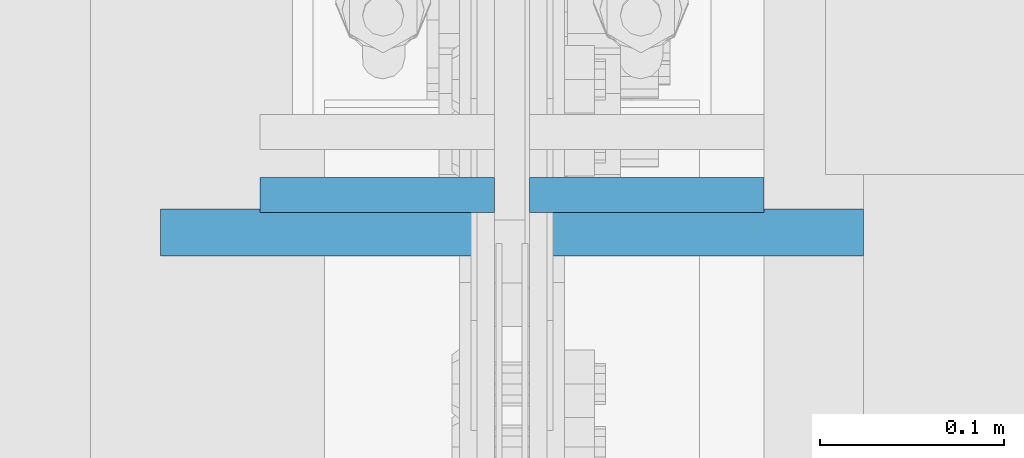
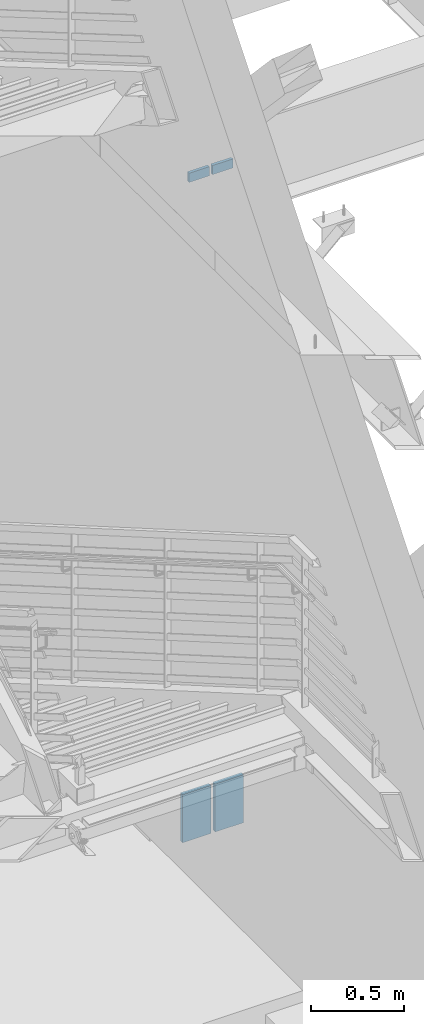
# One storey, part 490 of 1179: 4 columns, 4 elements without a shape of their own.
"""IFC2X3 building model written with IfcOpenShell, lengths in millimetres."""

from ifc_helpers import new_model, si_unit, frame, origin_with_axes, place, context, subcontext, project, spatial, faceted_brep, material, type_object, element, aggregate, save


model = new_model("IFC2X3")

# Units and contexts
model_context = context("Model", 3, precision=1e-05, world=origin_with_axes())
body_context = subcontext(model_context, "Body", "Model", "MODEL_VIEW")
ifc_project = project(units=[si_unit("LENGTHUNIT", "METRE", prefix="MILLI"), si_unit("AREAUNIT", "SQUARE_METRE"), si_unit("VOLUMEUNIT", "CUBIC_METRE"), si_unit("MASSUNIT", "GRAM", prefix="KILO"), si_unit("TIMEUNIT", "SECOND"), si_unit("PLANEANGLEUNIT", "RADIAN"), si_unit("SOLIDANGLEUNIT", "STERADIAN"), si_unit("THERMODYNAMICTEMPERATUREUNIT", "DEGREE_CELSIUS"), si_unit("LUMINOUSINTENSITYUNIT", "LUMEN")], contexts=[model_context])

# Site, building, storey
site_placement = place(None, origin_with_axes())
site = spatial("IfcSite", under=ifc_project, at=site_placement, CompositionType="ELEMENT")
building_placement = place(site_placement, origin_with_axes())
building = spatial("IfcBuilding", under=site, at=building_placement, Name="Undefined", CompositionType="ELEMENT")
storey_placement = place(building_placement, origin_with_axes())
storey = spatial("IfcBuildingStorey", under=building, at=storey_placement, Name="Undefined", CompositionType="ELEMENT", Elevation=0.0)

# Assembly, column
assembly_1_placement = place(storey_placement, origin_with_axes())
assembly_1 = element("IfcElementAssembly", 1, at=assembly_1_placement, inside=storey, Name="PLATE", AssemblyPlace="NOTDEFINED", PredefinedType="RIGID_FRAME")
ifc_material = material(Name="STEEL/A572-GR.50")
column_type_1 = type_object("IfcColumnType", PredefinedType="NOTDEFINED")
column_1_placement = place(assembly_1_placement, frame((330.2, 33931.2801619231, -215.9), z_axis=(1.0, 0.0, 0.0), x_axis=(0.0, 0.0, 1.0)))
column_1 = element("IfcColumn", 2, at=column_1_placement, type_object=column_type_1, material=ifc_material, Name="PLATE", context=body_context, shape_type="Brep", body=[
    faceted_brep([(0.0, 12.6999999999998, -88.9000000000015), (0.0, 12.6999999999998, 88.9000000000015), (314.840055491836, 12.7000000000007, 88.9000000000015), (314.840055491836, 12.7000000000007, -88.9000000000015), (0.0, -12.6999999999998, 88.9000000000015), (314.840055491836, -12.7000000000007, 88.9000000000015), (0.0, -12.6999999999998, -88.9000000000015), (314.840055491836, -12.7000000000007, -88.9000000000015)], [[[0, 1, 2, 3]], [[1, 4, 5, 2]], [[4, 6, 7, 5]], [[6, 0, 3, 7]], [[5, 7, 3, 2]], [[6, 4, 1, 0]]]),
])
aggregate(assembly_1, [column_1])

assembly_2_placement = place(storey_placement, origin_with_axes())
assembly_2 = element("IfcElementAssembly", 3, at=assembly_2_placement, inside=storey, Name="PLATE", AssemblyPlace="NOTDEFINED", PredefinedType="RIGID_FRAME")
column_2_placement = place(assembly_2_placement, frame((533.4, 33931.2801619231, -215.9), z_axis=(-1.0, 0.0, 0.0), x_axis=(0.0, 0.0, 1.0)))
column_2 = element("IfcColumn", 4, at=column_2_placement, type_object=column_type_1, material=ifc_material, Name="PLATE", context=body_context, shape_type="Brep", body=[
    faceted_brep([(0.0, 12.6999999999998, -88.9000000000015), (0.0, 12.6999999999998, 88.9000000000015), (314.840055491836, 12.7000000000007, 88.9000000000015), (314.840055491836, 12.7000000000007, -88.9000000000015), (0.0, -12.6999999999998, 88.9000000000015), (314.840055491836, -12.7000000000007, 88.9000000000015), (0.0, -12.6999999999998, -88.9000000000015), (314.840055491836, -12.7000000000007, -88.9000000000015)], [[[0, 1, 2, 3]], [[1, 4, 5, 2]], [[4, 6, 7, 5]], [[6, 0, 3, 7]], [[5, 7, 3, 2]], [[6, 4, 1, 0]]]),
])
aggregate(assembly_2, [column_2])

assembly_3_placement = place(storey_placement, origin_with_axes())
assembly_3 = element("IfcElementAssembly", 5, at=assembly_3_placement, inside=storey, Name="PLATE", AssemblyPlace="NOTDEFINED", PredefinedType="RIGID_FRAME")
column_type_2 = type_object("IfcColumnType", PredefinedType="NOTDEFINED")
column_3_placement = place(assembly_3_placement, frame((358.775000000002, 33951.641998869, 4102.1), z_axis=(1.0, 0.0, 0.0), x_axis=(0.0, 0.0, 1.0)))
column_3 = element("IfcColumn", 6, at=column_3_placement, type_object=column_type_2, material=ifc_material, Name="PLATE", context=body_context, shape_type="Brep", body=[
    faceted_brep([(0.0, 9.52500000000146, -63.5), (0.0, 9.52500000000146, 63.5), (59.8857973215509, 9.52500000000146, 63.5), (59.8857973215509, 9.52500000000146, -63.5), (0.0, -9.52500000000146, 63.5), (59.8857973215509, -9.52500000000146, 63.5), (0.0, -9.52500000000146, -63.5), (59.8857973215509, -9.52500000000146, -63.5)], [[[0, 1, 2, 3]], [[1, 4, 5, 2]], [[4, 6, 7, 5]], [[6, 0, 3, 7]], [[5, 7, 3, 2]], [[6, 4, 1, 0]]]),
])
aggregate(assembly_3, [column_3])

assembly_4_placement = place(storey_placement, origin_with_axes())
assembly_4 = element("IfcElementAssembly", 7, at=assembly_4_placement, inside=storey, Name="PLATE", AssemblyPlace="NOTDEFINED", PredefinedType="RIGID_FRAME")
column_4_placement = place(assembly_4_placement, frame((504.824713611823, 33951.641998869, 4102.1), z_axis=(-1.0, 0.0, 0.0), x_axis=(0.0, 0.0, 1.0)))
column_4 = element("IfcColumn", 8, at=column_4_placement, type_object=column_type_2, material=ifc_material, Name="PLATE", context=body_context, shape_type="Brep", body=[
    faceted_brep([(0.0, 9.52500000000146, -63.5), (0.0, 9.52500000000146, 63.5), (59.8857973215509, 9.52500000000146, 63.5), (59.8857973215509, 9.52500000000146, -63.5), (0.0, -9.52500000000146, 63.5), (59.8857973215509, -9.52500000000146, 63.5), (0.0, -9.52500000000146, -63.5), (59.8857973215509, -9.52500000000146, -63.5)], [[[0, 1, 2, 3]], [[1, 4, 5, 2]], [[4, 6, 7, 5]], [[6, 0, 3, 7]], [[5, 7, 3, 2]], [[6, 4, 1, 0]]]),
])
aggregate(assembly_4, [column_4])

save(model, "model.ifc")
